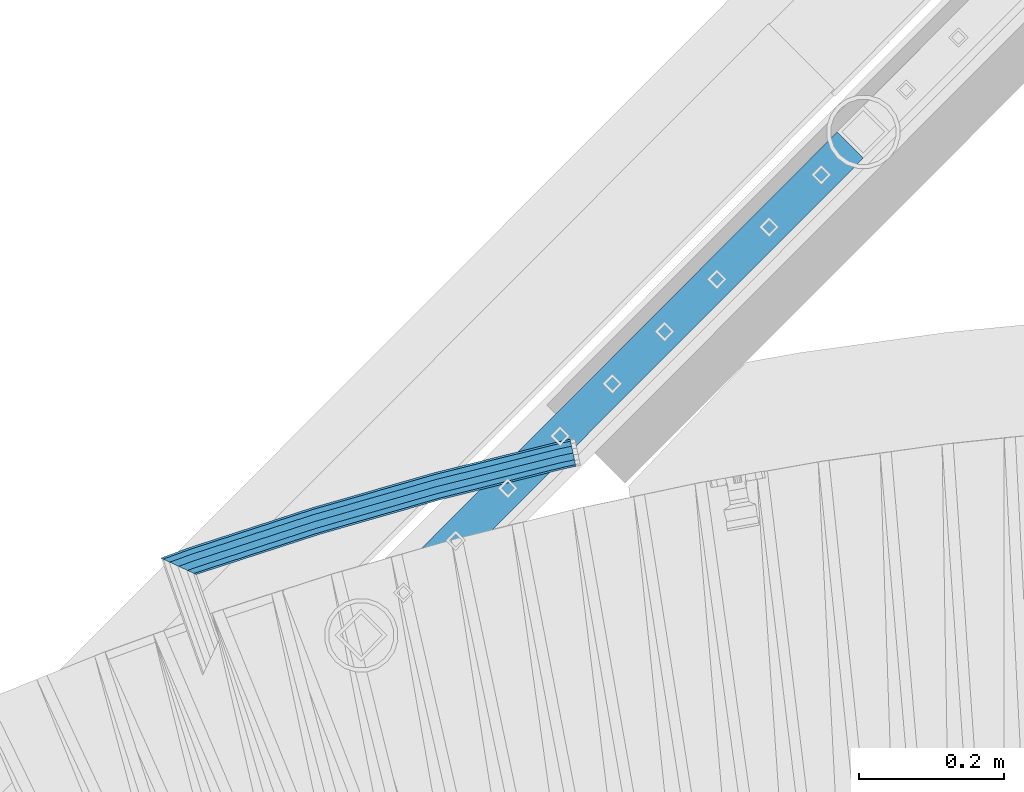
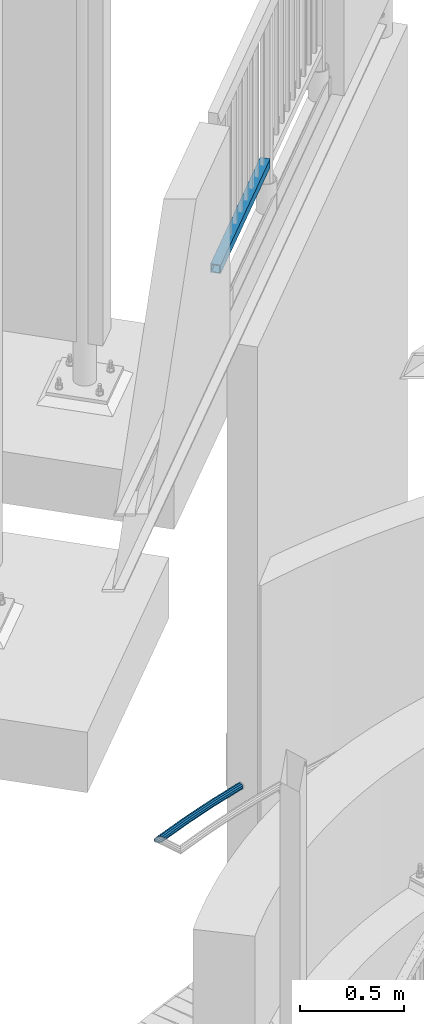
# One storey, part 518 of 975: 2 beams.
"""IFC2X3 building model written with IfcOpenShell, lengths in millimetres."""

from ifc_helpers import new_model, si_unit, frame, origin_with_axes, place, context, subcontext, project, spatial, faceted_brep, material, type_object, element, save


model = new_model("IFC2X3")

# Units and contexts
model_context = context("Model", 3, precision=1e-05, world=origin_with_axes())
body_context = subcontext(model_context, "Body", "Model", "MODEL_VIEW")
ifc_project = project(units=[si_unit("LENGTHUNIT", "METRE", prefix="MILLI"), si_unit("AREAUNIT", "SQUARE_METRE"), si_unit("VOLUMEUNIT", "CUBIC_METRE"), si_unit("MASSUNIT", "GRAM", prefix="KILO"), si_unit("TIMEUNIT", "SECOND"), si_unit("PLANEANGLEUNIT", "RADIAN"), si_unit("SOLIDANGLEUNIT", "STERADIAN"), si_unit("THERMODYNAMICTEMPERATUREUNIT", "DEGREE_CELSIUS"), si_unit("LUMINOUSINTENSITYUNIT", "LUMEN")], contexts=[model_context])

# Site, building, storey
site_placement = place(None, origin_with_axes())
site = spatial("IfcSite", under=ifc_project, at=site_placement, CompositionType="ELEMENT")
building_placement = place(site_placement, origin_with_axes())
building = spatial("IfcBuilding", under=site, at=building_placement, Name="Undefined", CompositionType="ELEMENT")
storey_placement = place(building_placement, origin_with_axes())
storey = spatial("IfcBuildingStorey", under=building, at=storey_placement, Name="Undefined", CompositionType="ELEMENT", Elevation=0.0)

# Beams
ifc_material = material()
beam_type_1 = type_object("IfcBeamType", PredefinedType="NOTDEFINED")
beam_1_placement = place(storey_placement, frame((32463.793439827, 7862.49208399872, 875.536914252329), z_axis=(-0.0509763858836195, -0.0248628449432381, 0.998390327989796), x_axis=(0.897347282750874, 0.437665512878495, 0.0567164259842538)))
element("IfcBeam", 1, at=beam_1_placement, inside=storey, type_object=beam_type_1, material=ifc_material, Name="HANDRAIL", context=body_context, shape_type="Brep", body=[
    faceted_brep([(697.433617748316, -36.4481424760306, 19.1341709101002), (698.428438497216, -26.9752205731002, 16.5820121954464), (666.903443565523, -23.6671995373372, 16.5721796791544), (675.648710393845, -34.1621807511547, 19.1273762870735), (696.440374911715, -45.9211991217744, 16.5818977546062), (684.076691813421, -44.6238373344913, 16.5780415726858), (695.71484860338, -52.8560926322525, 9.60907225984306), (689.929117009069, -52.2489768543519, 9.60726771394889), (695.451443011694, -55.3946238917333, 0.0840573860955374), (691.637833375837, -54.9944493342136, 0.0828679369316205), (695.720737452259, -52.8565954992828, -9.44092682332132), (688.744991743162, -52.1246076402567, -9.44310252972434), (696.450574697174, -45.9220701130171, -16.4136685415743), (682.025726690354, -44.4084235367818, -16.4181675923548), (697.445395446073, -36.4491482100866, -18.9658272562282), (673.280459862039, -33.9134423229643, -18.9733642002737), (698.438638282674, -26.9760915643437, -16.4135541007344), (664.852478442463, -23.4517857396258, -16.4240294858863), (699.164164591017, -20.0411980538656, -9.440728605971), (659.000053246815, -15.8266462197644, -9.45325562714913), (699.427570182688, -17.5026667943839, 0.0842862677761786), (657.291336880047, -13.0811737399017, 0.0711441498685872), (699.158275742124, -20.0406951868354, 9.60927047719338), (660.184178512722, -15.9510154338604, 9.59711461652398), (699.418971236166, -27.0791604196929, 16.582321138535), (700.270492935484, -20.1574037820301, 9.60961737316245), (700.585163781139, -17.6241368844758, 0.0846473164597228), (700.278667974151, -20.1581465464442, -9.44038099694876), (699.433130818474, -27.0804469253962, -16.4132439226015), (698.27511331216, -36.5362132250302, -18.9655684706374), (697.114905310842, -45.9917805015348, -16.4134613395878), (696.263383611516, -52.9135371391985, -9.44075757421535), (695.948712765869, -55.4468040367519, 0.0842124824873736), (696.255208572857, -52.9127943747835, 9.60924079589597), (697.100745728527, -45.9904939958315, 16.5821037215488), (698.25876323484, -36.5347276961993, 19.1344282695845), (699.080401914765, -36.6499310709651, 19.1348854719688), (700.405290585408, -27.2174810000633, 16.582829932496), (701.377973890707, -20.3127541694157, 9.61016427379661), (701.737822124527, -17.7858665572576, 0.0852086282101254), (701.388414243233, -20.3138956586308, -9.43983283108537), (700.423373806418, -27.2194581173771, -16.4127329371992), (699.101282619817, -36.6522140493971, -18.9651087377955), (697.776393949167, -46.0846641202997, -16.4130531983229), (696.803710643868, -52.9893909509474, -9.4403875396232), (696.443862410048, -55.5162785631046, 0.0845681059627168), (696.793270291357, -52.9882494617323, 9.60960956525867), (697.758310728164, -46.0826870029859, 16.5825096713726), (869.351796672305, -70.1589961320478, 16.67799416534), (870.67388785892, -60.7262402000315, 19.230369965936), (871.998776529541, -51.2937901291252, 16.6783144264639), (872.97145983484, -44.3890632984776, 9.70564876776439), (873.331308068675, -41.8621756863204, 0.1806931221779), (872.981900187366, -44.3902047876936, -9.34434833711794), (872.016859750565, -51.2957672464418, -16.3172484432318), (870.69476856395, -60.728523178459, -18.8696242438278), (869.369879893322, -70.1609732493644, -16.3175687043557), (868.397196588016, -77.0657000800084, -9.34490304565577), (868.037348354188, -79.5925876921665, 0.180052599930491), (868.38675623549, -77.0645585907932, 9.70509405922633), (868.92448719982, -77.1400077073768, 9.70539328369114), (870.008787769551, -70.2511786567256, 16.6783597530086), (871.494862289506, -60.8414312521218, 19.2308268033717), (872.984518292153, -51.4320997116092, 16.6788629499281), (874.078603654587, -44.5444068227844, 9.7062648463218), (874.483959087494, -42.0239043329202, 0.181334523561191), (874.091969929974, -44.5459588486965, -9.343730630408), (873.007669360235, -51.4347878993476, -16.3166970997255), (871.52159484028, -60.8445353039506, -18.8691641500884), (870.031938837634, -70.253866844464, -16.317200296645), (868.9378534752, -77.141559733288, -9.34460219303878), (868.532498042285, -79.6620622231494, 0.180328129721829), (869.024926262038, -79.7487465633849, 0.180861192139332), (869.459271601216, -77.234095931406, 9.70594954509636), (870.662183405806, -70.3661082846966, 16.6789819328876), (872.311342429221, -60.9850553668211, 19.231539958408), (873.964857842951, -51.6045827312728, 16.6796677600864), (875.179671527188, -44.7381804453726, 9.70713743265003), (875.630275136307, -42.2256954565355, 0.182232846536976), (875.195929797137, -44.7403460885125, -9.34285550642028), (873.993017992532, -51.6083337352193, -16.3158878942111), (872.343858969118, -60.9893866530974, -18.8684459197319), (870.690343555401, -70.3698592886458, -16.3165737214104), (869.475529871157, -77.2362615745451, -9.34404339397372), (1040.14562173188, -107.28007918462, -9.19496908067538), (1039.69501812276, -109.792564173457, 0.329935505437447), (1040.12936346193, -107.277913541479, 9.85502385839459), (1041.33227526654, -100.409925894774, 16.8280562461856), (1042.98143428996, -91.0288729768963, 19.380614271706), (1044.63494970368, -81.648400341347, 16.8287420733844), (1045.84976338792, -74.7819980554459, 9.85621174594814), (1046.30036699705, -72.2695130666107, 0.331307159834978), (1045.86602165787, -74.7841636985886, -9.19378119312205), (1044.66310985327, -81.6521513452944, -16.1668135809133), (1043.01395082985, -91.0332042631735, -18.719371606434), (1041.36043541613, -100.413676898719, -16.167499408112), (1042.01941109224, -100.529679326601, -16.1669238160716), (1040.68362900643, -107.374787005148, -9.19449915027292), (1040.18744643042, -109.879248525121, 0.330365624218189), (1040.66381508473, -107.371995444769, 9.85549068306057), (1041.98509237316, -100.524844202195, 16.8286264589326), (1043.7972431133, -91.1724834432998, 19.381326851976), (1045.61470297775, -81.8208706807491, 16.829597853357), (1046.95048506355, -74.9757630022023, 9.85717318755803), (1047.44666763956, -72.47130148223, 0.332308413067153), (1046.97029898524, -74.9785545625782, -9.19281664577511), (1045.64902169682, -81.8257058051531, -16.1659524216469), (1043.83687095669, -91.1780665640536, -18.7186528146908), (1044.6542178393, -91.3516354505209, -18.7176188994659), (1042.67392206073, -100.668677350531, -16.1660329869294), (1041.217996497, -107.488243624022, -9.19371426210148), (1040.67655522714, -109.983036995282, 0.331110103327546), (1041.19467700217, -107.484579595198, 9.8562711125918), (1042.63353151088, -100.662331066448, 16.8295095654836), (1044.60757884965, -91.344307392872, 19.3823518499202), (1046.58787462822, -82.0272654928622, 16.830765937383), (1048.04380019196, -75.2076992193743, 9.85844721255489), (1048.58524146182, -72.7129058481105, 0.333622847126549), (1048.06711968679, -75.2113632481987, -9.19153816213827), (1046.62826517807, -82.0336117769466, -16.1647766150297), (1216.12840246532, -118.001393483979, -15.9503699115129), (1214.15435512655, -127.319417157553, -18.5032121959497), (1212.17405934797, -136.636459057563, -15.9516262834126), (1210.71813378423, -143.456025331052, -8.97930755858442), (1210.17669251438, -145.950818702314, 0.545516806843693), (1210.69481428941, -143.452361302227, 10.0706778161087), (1212.13366879813, -136.630112773478, 17.0439162690002), (1214.10771613689, -127.312089099905, 19.5967585534368), (1216.08801191546, -117.995047199894, 17.0451726408996), (1217.5439374792, -111.175480926403, 10.0728539160718), (1218.08537874906, -108.680687555144, 0.54802955064315), (1217.56725697403, -111.179144955227, -8.97713145862133), (1218.66439722792, -111.411957162848, -8.97574364720765), (1217.10821237226, -118.209308294026, -15.9491305153945), (1214.97236155616, -127.492997410441, -18.5021774707579), (1212.82914428095, -136.775467510567, -15.9507976433699), (1211.25283388472, -143.569488227313, -8.97863119756391), (1210.66580146518, -146.054607196262, 0.54613549801104), (1211.22534188505, -143.56493879659, 10.0713488991811), (1212.78152674072, -136.767587665414, 17.0447357673676), (1214.91737755682, -127.483898549, 19.5977827227312), (1217.06059483204, -118.201428448873, 17.0464028953429), (1218.63690522826, -111.407407732128, 10.074236449537), (1219.22393764781, -108.922288763179, 0.549469753962057), (1220.35338732148, -109.203411098985, 0.551278855244277), (1219.75274166234, -111.682924893618, -8.97398586236716), (1218.08015197726, -118.451358683229, -15.9475200873668), (1215.78378732166, -127.695116099864, -18.5007709557746), (1213.4789567505, -136.937339808708, -15.9495969593271), (1211.78323775403, -143.701583430712, -8.97758311012399), (1211.15099686795, -146.175373349945, 0.547125111323226), (1211.7516425271, -143.695859555311, 10.0723898289347), (1213.42423221217, -136.927425765704, 17.0459240539337), (1215.72059686778, -127.683668349067, 19.5991749223421), (1218.02542743893, -118.441444640221, 17.0480009258947), (1219.72114643539, -111.677201018219, 10.0759870766911), (1236.01307498242, -115.732295633231, 10.1042263838034), (1236.12223802282, -113.128310559437, 0.578611495237169), (1234.99462295449, -115.476660581328, -8.94756663486248), (1232.93237332433, -122.148107206992, -15.9217762695789), (1230.48806725537, -131.355041700736, -18.4752835694459), (1228.31665458483, -140.630473400199, -15.9238783155967), (1226.9999635842, -147.489057872053, -8.95120748536431), (1226.8908005438, -150.093042945847, 0.574407403201803), (1228.01841561214, -147.744692923955, 10.1005855333012), (1230.08066524227, -141.073246298289, 17.0747951680185), (1232.52497131125, -131.866311804544, 19.6283024678852), (1234.69638398179, -122.590880105084, 17.076897214036), (696.048282482192, -49.6839861563431, 7.76759150948089), (696.633540370913, -44.0898387245579, 13.3923374085897), (697.326209620554, -44.1625227790219, 13.3925534492809), (696.644142981651, -49.7465117513784, 7.76777735592054), (698.015933492399, -44.2592415440431, 13.3929695525442), (697.237467540032, -49.8297285940989, 7.76816346694557), (869.609419436532, -68.3355506731041, 13.4884540465116), (868.830953484186, -73.9060377231635, 7.86364796091266), (870.298679656651, -68.4322608835118, 13.4888375905775), (869.424010530394, -73.9892496510365, 7.8639779719947), (870.984164082529, -68.5528567449155, 13.489477849601), (870.013815226823, -74.0930334465957, 7.86456505678279), (1041.65425594326, -98.5966743549916, 13.6385521628993), (1040.68390708754, -104.136851056668, 8.01363937008114), (1042.33927220779, -98.7172608238143, 13.6391505004764), (1041.27344186179, -104.240629492828, 8.01415430793975), (1043.01968909872, -98.8615548684638, 13.6400619013669), (1041.85901312835, -104.36483534832, 8.01498288270113), (1212.51982638595, -134.829336575493, 13.8544686048839), (1211.3591504156, -140.332617055353, 8.22938958621796), (1213.19977301843, -134.973620659512, 13.8553286933676), (1211.9444505682, -140.456817238662, 8.23012995302997), (1213.87430445612, -135.14140594773, 13.8565577869415), (1212.52508211017, -140.601275871348, 8.23124017877524), (1230.35633035688, -139.243816186132, 13.8851265957176), (1228.6927823219, -144.625449797503, 8.25926415704544), (1215.72670527832, -127.684774964977, 15.9161801541244), (1232.32807058585, -131.816889027845, 15.9449558176098), (1214.92269267676, -127.484778105605, 15.914786570694), (1214.11222457256, -127.31279747881, 15.9137613809962), (1044.61208728532, -91.3450157717771, 15.6993546774795), (1043.80107380483, -91.173023144971, 15.6983288175314), (1042.98457755548, -91.0292916679009, 15.6976156368195), (872.314485694751, -60.9854740578285, 15.5485413235212), (871.497446436075, -60.8417313104646, 15.5478276778705), (870.675906327069, -60.7264608879441, 15.5473705256591), (699.082420382922, -36.6501517588822, 15.4518860316916), (698.26034374232, -36.5348712973191, 15.4514285846965), (697.434756259096, -36.4482396969897, 15.4511710873547), (698.237244996544, -28.8067493619583, 13.3924297242013), (699.196244863389, -28.9073803609381, 13.3927288323163), (700.15116391057, -29.041308701685, 13.3932278965168), (871.744649854711, -53.1176178307469, 13.4887123904847), (872.69910227822, -53.2515372011194, 13.4892435027595), (873.648321461809, -53.4185594651499, 13.4900310835421), (1044.31841332255, -83.462377075225, 13.6391053968399), (1045.26715809547, -83.6293888498467, 13.6399340919789), (1046.20952588003, -83.829268639106, 13.6410753746995), (1215.70966316728, -119.797050346137, 13.855482078216), (1216.6515546121, -119.996918891502, 13.856673509934), (1217.58593527238, -120.229381173175, 13.858233130323), (1234.07967680675, -124.334707456946, 13.8868222461712), (1218.95381526287, -114.772891318094, 8.23414195863234), (1235.14180754726, -118.802115982983, 8.26220110978375), (1217.92311166505, -114.51640884666, 8.23245924365051), (1216.88410978869, -114.295933552186, 8.23114497352185), (1047.38397250145, -78.3281518451577, 8.01673827000491), (1046.34468897803, -78.107668655819, 8.01551152823458), (1045.29836302784, -77.9234792312682, 8.01459759937461), (874.628271167105, -47.8796616211912, 7.86552328607638), (873.581664470581, -47.6954649374684, 7.86468103251707), (872.529281054321, -47.547804854029, 7.8640954258002), (700.935795110181, -23.4714957249644, 7.76861093183243), (699.883139034169, -23.3238300065577, 7.76808112824904), (698.825980374113, -23.2128988837067, 7.76775140480981), (699.043211222826, -21.1655559804594, 0.0842641425471129), (700.136973516328, -21.2803280425305, 0.0846052825091874), (701.226072685469, -21.4331397178248, 0.0851467110597923), (872.819558629602, -45.5094488468867, 0.180631205027453), (873.908651186455, -45.6622595956433, 0.181237238823542), (874.991758078464, -45.8529237301973, 0.18210025327835), (1045.6618499392, -75.8967413402725, 0.331174566576578), (1046.74494292268, -76.0874030297082, 0.332120610145353), (1047.8207351258, -76.3156851923404, 0.333379948559127), (1217.32087241304, -112.283466899369, 0.54778665207607), (1218.39665115015, -112.511746211711, 0.549147442553362), (1219.46382291097, -112.777367449911, 0.550877326665386), (1217.94528854478, -114.520078720775, -7.13452470105642), (1218.97930207927, -114.777508577584, -7.13283621220808), (1216.90292084785, -114.298889202104, -7.13584322873089), (1047.4027835606, -78.3311074950725, -7.35024993224738), (1046.3606722082, -78.1099205145256, -7.35148027065463), (1045.31147803226, -77.9252261833999, -7.35239670480883), (874.641386171523, -47.8814085733247, -7.50147101810694), (873.592446599392, -47.6967169050367, -7.50231531871157), (872.537702938684, -47.548725655327, -7.5029022388045), (700.944216994551, -23.4724165262642, -7.59838673277227), (699.889733565349, -23.3244291698493, -7.59891755697356), (698.830730712205, -23.2133045297742, -7.59924785560884), (698.245472823477, -28.8074519615602, -13.2239937547178), (699.207666926446, -28.9084181422068, -13.2236936503338), (700.165751042183, -29.04290357632, -13.2231928183708), (871.759236986331, -53.1192127053819, -13.127708324403), (872.717777473135, -53.2537056725596, -13.1271749372944), (873.671037315824, -53.4215852750049, -13.1263838109252), (1044.34112917656, -83.4654028850782, -12.9773094976272), (1045.29484186219, -83.6332891835336, -12.976476463191), (1046.24210759024, -83.8343879749336, -12.9753289509133), (1215.74224487748, -119.802169681962, -12.7609222473965), (1216.68996609454, -120.003275299926, -12.7597234413938), (1217.63007973331, -120.237378501202, -12.7581538203744), (1214.96704643622, -127.492117853833, -14.8191813187208), (1215.77767891111, -127.694009483953, -14.8177761875567), (1214.14984669089, -127.318708778647, -14.8202150235089), (1044.64970940363, -91.3509270716158, -15.0346217270255), (1043.83304026517, -91.1775268623787, -15.0356547802463), (1043.01080756433, -91.0327855721671, -15.0363729715472), (872.340715703594, -60.988967962091, -15.1854472848452), (871.519010693704, -60.8442352456077, -15.1861650245874), (870.692750095801, -60.7283024905428, -15.1866248035504), (699.099264151653, -36.65199336148, -15.2821092975182), (698.273532804687, -36.5360696239086, -15.2825687857495), (697.444256935287, -36.4490509891266, -15.2828274334829), (696.641768197846, -44.0905413241599, -13.2240860703292), (697.337631683618, -44.1635605602896, -13.2238690333692), (698.030520624012, -44.2608364186772, -13.223451162344), (869.624006568152, -68.3371455477409, -13.1279666683763), (870.317354851566, -68.434429354952, -13.1275808494762), (871.006879936529, -68.555882554766, -13.1269370448656), (1041.67697179727, -98.5997001648411, -12.9778627315675), (1042.3669559745, -98.7211611575021, -12.9772600546933), (1043.05227080892, -98.8666742042878, -12.9763424242456), (1212.55240809617, -134.834455911323, -12.7619357207291), (1213.23818450088, -134.979977067937, -12.761068257961), (1213.91844891705, -135.149403275757, -12.759829163756), (1211.96662744792, -140.460487112778, -7.1368539916773), (1212.55056892657, -140.605893130838, -7.13573799206495), (1211.37796147475, -140.335572705271, -7.13759861603467), (1041.87782418751, -104.36779099824, -7.35200531955138), (1041.28942509195, -104.242881351529, -7.35283749094913), (1040.69702209197, -104.138598008801, -7.35335493410196), (870.026930231234, -74.0947803987237, -7.50242924740007), (869.434792659205, -73.9905016186058, -7.50301837923405), (868.839375368549, -73.9069585244615, -7.50334970369181), (697.245889424394, -49.8306493953978, -7.59883419765924), (696.650737512831, -49.7471109146709, -7.59922132930194), (696.053032820277, -49.6843918024115, -7.59940775093787), (695.835801971563, -51.7317347056587, 0.0840795113247168), (696.396903030673, -51.790612878699, 0.0842545164381363), (696.95561184912, -51.8690054025383, 0.084630023113391), (868.54909779326, -75.9453145316029, 0.18011451708071), (869.107805943331, -76.02370696043, 0.180425414459705), (869.663443319881, -76.1215182897231, 0.180993785397504), (1040.33353518061, -106.165335899796, 0.330068098695847), (1040.88917114731, -106.263146977641, 0.330553427140217), (1041.44106156316, -106.380257651055, 0.331353001894399), (1210.9411988504, -142.348039358088, 0.545759705411115), (1211.49308796283, -142.465149747731, 0.546457809419735), (1212.04056127846, -142.601416999019, 0.547526639902458), (1227.78317283343, -146.519785481827, 0.574813798765717), (1227.87123101936, -144.4192375223, -7.109182211345), (1228.93336175986, -138.886646048339, -12.7338033477323), (1230.68496798077, -131.404464477442, -14.7919369191709), (1232.65670820974, -123.97753731915, -12.732107697278), (1234.32025624473, -118.595903707781, -7.10624525860646), (1235.22986573319, -116.701568023455, 0.578205099673596), (688.317672047913, -50.9428326934321, 0.0817346375151828), (686.939307512042, -48.728151559676, 7.76475045764278), (682.218351187559, -42.5772056803216, 13.3878413703571), (675.419779509099, -34.1381360364276, 15.4443047066297), (668.365264267599, -25.6721845239499, 13.3831127762415), (662.945057124994, -19.4477960138138, 7.75656029238644), (660.611498207971, -17.1327903806878, 0.0722774492844565), (661.989862743834, -19.347471514443, -7.61073837084325), (666.710819068318, -25.4984173937974, -13.2338292835576), (673.509390746771, -33.937487037686, -15.2902926198299), (680.563905988285, -42.4034385501664, -13.2291006894421), (685.984113130889, -48.6278270603052, -7.60254820558691)], [[[0, 1, 2, 3]], [[4, 0, 3, 5]], [[6, 4, 5, 7]], [[8, 6, 7, 9]], [[10, 8, 9, 11]], [[12, 10, 11, 13]], [[14, 12, 13, 15]], [[16, 14, 15, 17]], [[18, 16, 17, 19]], [[20, 18, 19, 21]], [[22, 20, 21, 23]], [[1, 22, 23, 2]], [[22, 1, 24, 25]], [[20, 22, 25, 26]], [[18, 20, 26, 27]], [[16, 18, 27, 28]], [[14, 16, 28, 29]], [[12, 14, 29, 30]], [[10, 12, 30, 31]], [[8, 10, 31, 32]], [[6, 8, 32, 33]], [[4, 6, 33, 34]], [[0, 4, 34, 35]], [[1, 0, 35, 24]], [[24, 35, 36, 37]], [[25, 24, 37, 38]], [[26, 25, 38, 39]], [[27, 26, 39, 40]], [[28, 27, 40, 41]], [[29, 28, 41, 42]], [[30, 29, 42, 43]], [[31, 30, 43, 44]], [[32, 31, 44, 45]], [[33, 32, 45, 46]], [[34, 33, 46, 47]], [[35, 34, 47, 36]], [[36, 47, 48, 49]], [[37, 36, 49, 50]], [[38, 37, 50, 51]], [[39, 38, 51, 52]], [[40, 39, 52, 53]], [[41, 40, 53, 54]], [[42, 41, 54, 55]], [[43, 42, 55, 56]], [[44, 43, 56, 57]], [[45, 44, 57, 58]], [[46, 45, 58, 59]], [[47, 46, 59, 48]], [[48, 59, 60, 61]], [[49, 48, 61, 62]], [[50, 49, 62, 63]], [[51, 50, 63, 64]], [[52, 51, 64, 65]], [[53, 52, 65, 66]], [[54, 53, 66, 67]], [[55, 54, 67, 68]], [[56, 55, 68, 69]], [[57, 56, 69, 70]], [[58, 57, 70, 71]], [[59, 58, 71, 60]], [[60, 71, 72, 73]], [[61, 60, 73, 74]], [[62, 61, 74, 75]], [[63, 62, 75, 76]], [[64, 63, 76, 77]], [[65, 64, 77, 78]], [[66, 65, 78, 79]], [[67, 66, 79, 80]], [[68, 67, 80, 81]], [[69, 68, 81, 82]], [[70, 69, 82, 83]], [[71, 70, 83, 72]], [[72, 83, 84, 85]], [[73, 72, 85, 86]], [[74, 73, 86, 87]], [[75, 74, 87, 88]], [[76, 75, 88, 89]], [[77, 76, 89, 90]], [[78, 77, 90, 91]], [[79, 78, 91, 92]], [[80, 79, 92, 93]], [[81, 80, 93, 94]], [[82, 81, 94, 95]], [[83, 82, 95, 84]], [[84, 95, 96, 97]], [[85, 84, 97, 98]], [[86, 85, 98, 99]], [[87, 86, 99, 100]], [[88, 87, 100, 101]], [[89, 88, 101, 102]], [[90, 89, 102, 103]], [[91, 90, 103, 104]], [[92, 91, 104, 105]], [[93, 92, 105, 106]], [[94, 93, 106, 107]], [[95, 94, 107, 96]], [[96, 107, 108, 109]], [[97, 96, 109, 110]], [[98, 97, 110, 111]], [[99, 98, 111, 112]], [[100, 99, 112, 113]], [[101, 100, 113, 114]], [[102, 101, 114, 115]], [[103, 102, 115, 116]], [[104, 103, 116, 117]], [[105, 104, 117, 118]], [[106, 105, 118, 119]], [[107, 106, 119, 108]], [[108, 119, 120, 121]], [[109, 108, 121, 122]], [[110, 109, 122, 123]], [[111, 110, 123, 124]], [[112, 111, 124, 125]], [[113, 112, 125, 126]], [[114, 113, 126, 127]], [[115, 114, 127, 128]], [[116, 115, 128, 129]], [[117, 116, 129, 130]], [[118, 117, 130, 131]], [[119, 118, 131, 120]], [[120, 131, 132, 133]], [[121, 120, 133, 134]], [[122, 121, 134, 135]], [[123, 122, 135, 136]], [[124, 123, 136, 137]], [[125, 124, 137, 138]], [[126, 125, 138, 139]], [[127, 126, 139, 140]], [[128, 127, 140, 141]], [[129, 128, 141, 142]], [[130, 129, 142, 143]], [[131, 130, 143, 132]], [[132, 143, 144, 145]], [[133, 132, 145, 146]], [[134, 133, 146, 147]], [[135, 134, 147, 148]], [[136, 135, 148, 149]], [[137, 136, 149, 150]], [[138, 137, 150, 151]], [[139, 138, 151, 152]], [[140, 139, 152, 153]], [[141, 140, 153, 154]], [[142, 141, 154, 155]], [[143, 142, 155, 144]], [[144, 155, 156, 157]], [[145, 144, 157, 158]], [[146, 145, 158, 159]], [[147, 146, 159, 160]], [[148, 147, 160, 161]], [[149, 148, 161, 162]], [[150, 149, 162, 163]], [[151, 150, 163, 164]], [[152, 151, 164, 165]], [[153, 152, 165, 166]], [[154, 153, 166, 167]], [[155, 154, 167, 156]], [[168, 169, 170, 171]], [[171, 170, 172, 173]], [[173, 172, 174, 175]], [[175, 174, 176, 177]], [[177, 176, 178, 179]], [[179, 178, 180, 181]], [[181, 180, 182, 183]], [[183, 182, 184, 185]], [[185, 184, 186, 187]], [[187, 186, 188, 189]], [[189, 188, 190, 191]], [[191, 190, 192, 193]], [[190, 194, 195, 192]], [[188, 196, 194, 190]], [[186, 197, 196, 188]], [[184, 198, 197, 186]], [[182, 199, 198, 184]], [[180, 200, 199, 182]], [[178, 201, 200, 180]], [[176, 202, 201, 178]], [[174, 203, 202, 176]], [[172, 204, 203, 174]], [[170, 205, 204, 172]], [[169, 206, 205, 170]], [[206, 207, 208, 205]], [[205, 208, 209, 204]], [[204, 209, 210, 203]], [[203, 210, 211, 202]], [[202, 211, 212, 201]], [[201, 212, 213, 200]], [[200, 213, 214, 199]], [[199, 214, 215, 198]], [[198, 215, 216, 197]], [[197, 216, 217, 196]], [[196, 217, 218, 194]], [[194, 218, 219, 195]], [[218, 220, 221, 219]], [[217, 222, 220, 218]], [[216, 223, 222, 217]], [[215, 224, 223, 216]], [[214, 225, 224, 215]], [[213, 226, 225, 214]], [[212, 227, 226, 213]], [[211, 228, 227, 212]], [[210, 229, 228, 211]], [[209, 230, 229, 210]], [[208, 231, 230, 209]], [[207, 232, 231, 208]], [[232, 233, 234, 231]], [[231, 234, 235, 230]], [[230, 235, 236, 229]], [[229, 236, 237, 228]], [[228, 237, 238, 227]], [[227, 238, 239, 226]], [[226, 239, 240, 225]], [[225, 240, 241, 224]], [[224, 241, 242, 223]], [[223, 242, 243, 222]], [[222, 243, 244, 220]], [[243, 245, 246, 244]], [[242, 247, 245, 243]], [[241, 248, 247, 242]], [[240, 249, 248, 241]], [[239, 250, 249, 240]], [[238, 251, 250, 239]], [[237, 252, 251, 238]], [[236, 253, 252, 237]], [[235, 254, 253, 236]], [[234, 255, 254, 235]], [[233, 256, 255, 234]], [[256, 257, 258, 255]], [[255, 258, 259, 254]], [[254, 259, 260, 253]], [[253, 260, 261, 252]], [[252, 261, 262, 251]], [[251, 262, 263, 250]], [[250, 263, 264, 249]], [[249, 264, 265, 248]], [[248, 265, 266, 247]], [[247, 266, 267, 245]], [[245, 267, 268, 246]], [[267, 269, 270, 268]], [[266, 271, 269, 267]], [[265, 272, 271, 266]], [[264, 273, 272, 265]], [[263, 274, 273, 264]], [[262, 275, 274, 263]], [[261, 276, 275, 262]], [[260, 277, 276, 261]], [[259, 278, 277, 260]], [[258, 279, 278, 259]], [[257, 280, 279, 258]], [[280, 281, 282, 279]], [[279, 282, 283, 278]], [[278, 283, 284, 277]], [[277, 284, 285, 276]], [[276, 285, 286, 275]], [[275, 286, 287, 274]], [[274, 287, 288, 273]], [[273, 288, 289, 272]], [[272, 289, 290, 271]], [[271, 290, 291, 269]], [[269, 291, 292, 270]], [[291, 293, 294, 292]], [[290, 295, 293, 291]], [[289, 296, 295, 290]], [[288, 297, 296, 289]], [[287, 298, 297, 288]], [[286, 299, 298, 287]], [[285, 300, 299, 286]], [[284, 301, 300, 285]], [[283, 302, 301, 284]], [[282, 303, 302, 283]], [[281, 304, 303, 282]], [[304, 305, 306, 303]], [[303, 306, 307, 302]], [[302, 307, 308, 301]], [[301, 308, 309, 300]], [[300, 309, 310, 299]], [[299, 310, 311, 298]], [[298, 311, 312, 297]], [[297, 312, 313, 296]], [[296, 313, 314, 295]], [[295, 314, 315, 293]], [[293, 315, 316, 294]], [[294, 316, 317, 318]], [[292, 294, 318, 319]], [[270, 292, 319, 320]], [[268, 270, 320, 321]], [[246, 268, 321, 322]], [[244, 246, 322, 323]], [[220, 244, 323, 221]], [[166, 165, 164, 163, 162, 161, 160, 159, 158, 157, 156, 167], [322, 321, 320, 319, 318, 317, 193, 192, 195, 219, 221, 323]], [[316, 191, 193, 317]], [[315, 189, 191, 316]], [[314, 187, 189, 315]], [[313, 185, 187, 314]], [[312, 183, 185, 313]], [[311, 181, 183, 312]], [[310, 179, 181, 311]], [[309, 177, 179, 310]], [[308, 175, 177, 309]], [[307, 173, 175, 308]], [[306, 171, 173, 307]], [[305, 168, 171, 306]], [[168, 305, 324, 325]], [[169, 168, 325, 326]], [[206, 169, 326, 327]], [[207, 206, 327, 328]], [[232, 207, 328, 329]], [[233, 232, 329, 330]], [[256, 233, 330, 331]], [[257, 256, 331, 332]], [[280, 257, 332, 333]], [[281, 280, 333, 334]], [[304, 281, 334, 335]], [[305, 304, 335, 324]], [[5, 3, 2, 23, 21, 19, 17, 15, 13, 11, 9, 7], [334, 333, 332, 331, 330, 329, 328, 327, 326, 325, 324, 335]]]),
])
beam_type_2 = type_object("IfcBeamType", Name="HSS2X2X.188_TUBES", PredefinedType="NOTDEFINED")
beam_2_placement = place(storey_placement, frame((33335.0272317401, 8032.31295415032, 4229.0999999425), z_axis=(-0.707767818912136, 0.706445124912302, 0.0), x_axis=(0.706445124912301, 0.707767818912137, -6.99999997968407e-09)))
element("IfcBeam", 2, at=beam_2_placement, inside=storey, type_object=beam_type_2, material=ifc_material, Name="HANDRAIL", ObjectType="HSS2X2X.188_TUBES", context=body_context, shape_type="Brep", body=[
    faceted_brep([(25.4066905447944, 20.6375000000089, -20.6374999998698), (25.4066902559134, -20.6374999999907, -20.6374999999498), (952.506351760483, -20.6374999996378, -20.6374999980435), (952.50631743492, 20.6375000003618, -20.6374999979598), (25.3933137092608, -20.6374999999907, 20.6374999999607), (952.492975213831, -20.6374999996378, 20.6375000018634), (25.3933139981382, 20.6375000000098, 20.637500000048), (952.492940888267, 20.6375000003618, 20.6375000019507), (25.4082340258137, 25.4000000000096, -25.399999999845), (25.3917705837775, 25.4000000000096, 25.4000000000487), (952.491393479933, 25.4000000003625, 25.4000000019478), (952.50785692197, 25.4000000003616, -25.3999999979424), (25.3917702282379, -25.3999999999905, 25.3999999999432), (952.491435726784, -25.3999999996377, 25.4000000018459), (25.4082336702741, -25.3999999999905, -25.3999999999505), (952.507899168821, -25.3999999996377, -25.3999999980442)], [[[0, 1, 2, 3]], [[1, 4, 5, 2]], [[4, 6, 7, 5]], [[6, 0, 3, 7]], [[8, 9, 10, 11]], [[9, 12, 13, 10]], [[12, 14, 15, 13]], [[14, 8, 11, 15]], [[13, 15, 11, 10], [5, 7, 3, 2]], [[14, 12, 9, 8], [6, 4, 1, 0]]]),
])

save(model, "model.ifc")
